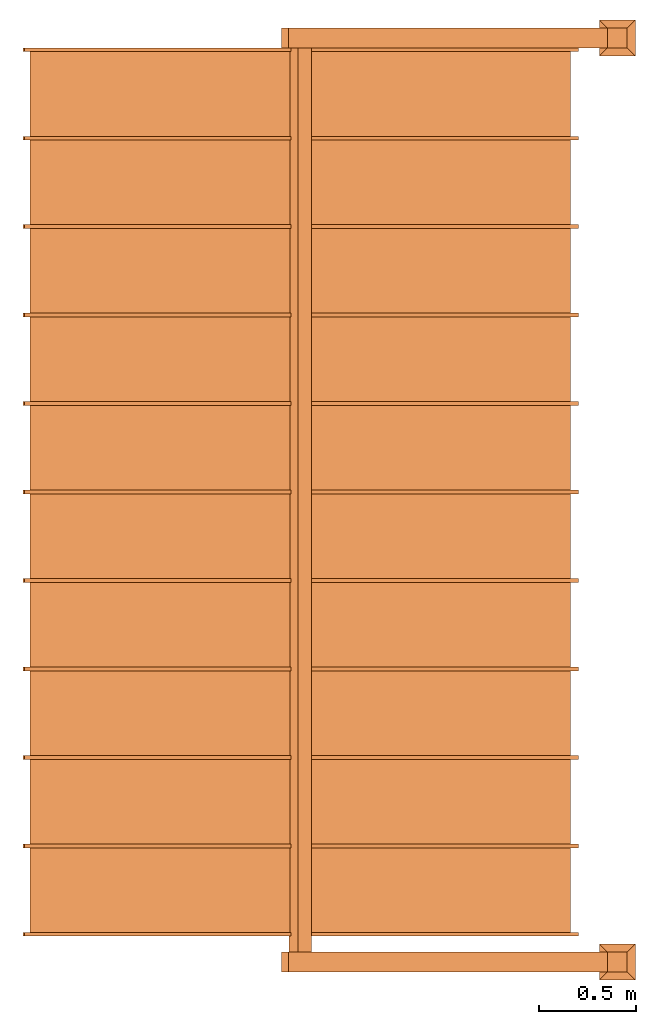
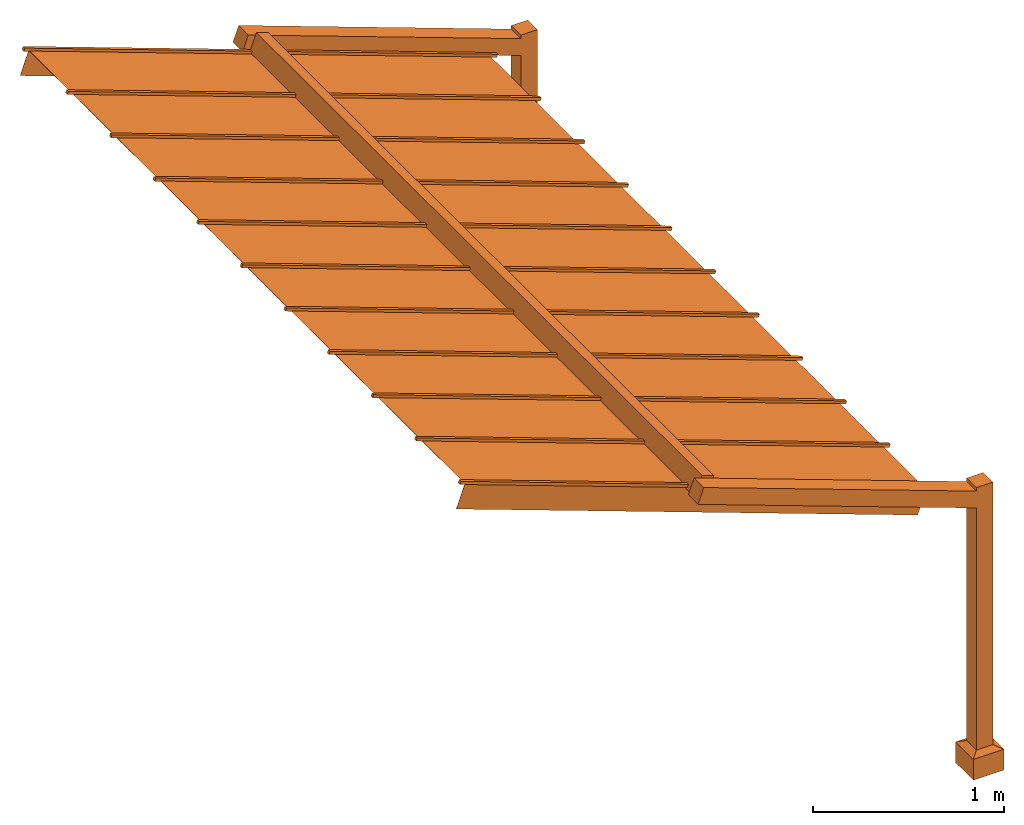
# One storey: 1 proxy.
"""IFC2X3 building model written with IfcOpenShell, lengths in feet."""

from ifc_helpers import new_model, entity, si_unit, converted_unit, derived_unit, direction, frame, origin, place, context, subcontext, project, spatial, faceted_brep, source, transform, mapped, material, material_list, type_object, type_shapes, element, save


model = new_model("IFC2X3")

# Units and contexts
model_context = context("Model", 3, precision=0.0001, world=origin(), true_north=direction((6.123031769111886e-17, 1.0)))
plan_context = context("Plan", 3, precision=0.0001, world=origin(), true_north=direction((6.123031769111886e-17, 1.0)))
body_context = subcontext(model_context, "Body", "Model", "MODEL_VIEW")
ifc_project = project(units=[converted_unit("LENGTHUNIT", "FOOT", entity("IfcRatioMeasure", 0.3048), si_unit("LENGTHUNIT", "METRE"), dimensions=[1, 0, 0, 0, 0, 0, 0]), converted_unit("AREAUNIT", "SQUARE FOOT", entity("IfcRatioMeasure", 0.09290304), si_unit("AREAUNIT", "SQUARE_METRE"), dimensions=[2, 0, 0, 0, 0, 0, 0]), converted_unit("VOLUMEUNIT", "CUBIC FOOT", entity("IfcRatioMeasure", 0.028316846592000004), si_unit("VOLUMEUNIT", "CUBIC_METRE"), dimensions=[3, 0, 0, 0, 0, 0, 0]), converted_unit("PLANEANGLEUNIT", "DEGREE", entity("IfcRatioMeasure", 0.017453292519943278), si_unit("PLANEANGLEUNIT", "RADIAN"), dimensions=[0, 0, 0, 0, 0, 0, 0]), si_unit("MASSUNIT", "GRAM", prefix="KILO"), derived_unit("MASSDENSITYUNIT", [(si_unit("MASSUNIT", "GRAM", prefix="KILO"), 1), (si_unit("LENGTHUNIT", "METRE"), -3)]), derived_unit("MOMENTOFINERTIAUNIT", [(si_unit("LENGTHUNIT", "METRE"), 4)]), si_unit("TIMEUNIT", "SECOND"), si_unit("FREQUENCYUNIT", "HERTZ"), si_unit("THERMODYNAMICTEMPERATUREUNIT", "DEGREE_CELSIUS"), derived_unit("THERMALTRANSMITTANCEUNIT", [(si_unit("MASSUNIT", "GRAM", prefix="KILO"), 1), (si_unit("THERMODYNAMICTEMPERATUREUNIT", "KELVIN"), -1), (si_unit("TIMEUNIT", "SECOND"), -3)]), derived_unit("VOLUMETRICFLOWRATEUNIT", [(si_unit("LENGTHUNIT", "METRE"), 3), (si_unit("TIMEUNIT", "SECOND"), -1)]), derived_unit("MASSFLOWRATEUNIT", [(si_unit("MASSUNIT", "GRAM", prefix="KILO"), 1), (si_unit("TIMEUNIT", "SECOND"), -1)]), derived_unit("ROTATIONALFREQUENCYUNIT", [(si_unit("TIMEUNIT", "SECOND"), -1)]), si_unit("ELECTRICCURRENTUNIT", "AMPERE"), si_unit("ELECTRICVOLTAGEUNIT", "VOLT"), si_unit("POWERUNIT", "WATT"), si_unit("FORCEUNIT", "NEWTON"), si_unit("ILLUMINANCEUNIT", "LUX"), si_unit("LUMINOUSFLUXUNIT", "LUMEN"), si_unit("LUMINOUSINTENSITYUNIT", "CANDELA"), derived_unit("USERDEFINED", [(si_unit("MASSUNIT", "GRAM", prefix="KILO"), -1), (si_unit("LENGTHUNIT", "METRE"), -2), (si_unit("TIMEUNIT", "SECOND"), 3), (si_unit("LUMINOUSFLUXUNIT", "LUMEN"), 1)]), derived_unit("SOUNDPOWERUNIT", [(si_unit("MASSUNIT", "GRAM", prefix="KILO"), 1), (si_unit("LENGTHUNIT", "METRE"), 2), (si_unit("TIMEUNIT", "SECOND"), -3)]), derived_unit("LINEARVELOCITYUNIT", [(si_unit("LENGTHUNIT", "METRE"), 1), (si_unit("TIMEUNIT", "SECOND"), -1)]), si_unit("PRESSUREUNIT", "PASCAL"), derived_unit("USERDEFINED", [(si_unit("LENGTHUNIT", "METRE"), -2), (si_unit("MASSUNIT", "GRAM", prefix="KILO"), 1), (si_unit("TIMEUNIT", "SECOND"), -2)]), derived_unit("LINEARFORCEUNIT", [(si_unit("MASSUNIT", "GRAM", prefix="KILO"), 1), (si_unit("LENGTHUNIT", "METRE"), 1), (si_unit("TIMEUNIT", "SECOND"), -2), (si_unit("LENGTHUNIT", "METRE"), -1)]), derived_unit("PLANARFORCEUNIT", [(si_unit("MASSUNIT", "GRAM", prefix="KILO"), 1), (si_unit("LENGTHUNIT", "METRE"), 1), (si_unit("TIMEUNIT", "SECOND"), -2), (si_unit("LENGTHUNIT", "METRE"), -2)])], contexts=[model_context, plan_context])

# Site, building, storey
site_placement = place(None, origin())
site = spatial("IfcSite", under=ifc_project, at=site_placement, CompositionType="ELEMENT")
building_placement = place(site_placement, origin())
building = spatial("IfcBuilding", under=site, at=building_placement, CompositionType="ELEMENT")
storey_placement = place(building_placement, origin())
storey = spatial("IfcBuildingStorey", under=building, at=storey_placement, Name="Level 1", CompositionType="ELEMENT", Elevation=0.0)

# Proxy
ifc_material_1 = material()
ifc_material_2 = material()
ifc_material_list_1 = material_list([ifc_material_1, ifc_material_2, ifc_material_1, ifc_material_2, ifc_material_1, ifc_material_2, ifc_material_1, ifc_material_2, ifc_material_1, ifc_material_2, ifc_material_1, ifc_material_2, ifc_material_1, ifc_material_2, ifc_material_1, ifc_material_2, ifc_material_1, ifc_material_2, ifc_material_1, ifc_material_2, ifc_material_2, ifc_material_2, ifc_material_1, ifc_material_1, ifc_material_1, ifc_material_1, ifc_material_1, ifc_material_1, ifc_material_1, ifc_material_1, ifc_material_1, ifc_material_1, ifc_material_1, ifc_material_1, ifc_material_1, ifc_material_1, ifc_material_1, ifc_material_1])
ifc_material_list_2 = material_list([ifc_material_1, ifc_material_2, ifc_material_1, ifc_material_2, ifc_material_1, ifc_material_2, ifc_material_1, ifc_material_2, ifc_material_1, ifc_material_2, ifc_material_1, ifc_material_2, ifc_material_1, ifc_material_2, ifc_material_1, ifc_material_2, ifc_material_1, ifc_material_2, ifc_material_1, ifc_material_2, ifc_material_2, ifc_material_2, ifc_material_1, ifc_material_1, ifc_material_1, ifc_material_1, ifc_material_1, ifc_material_1, ifc_material_1, ifc_material_1, ifc_material_1, ifc_material_1, ifc_material_1, ifc_material_1, ifc_material_1, ifc_material_1, ifc_material_1, ifc_material_1])
building_element_proxy_type = type_object("IfcBuildingElementProxyType", PredefinedType="NOTDEFINED", material=ifc_material_list_2)
shared_shape = source(origin(), body_context, "Body", "Brep", [
    faceted_brep([(-4.481523158329109, 3.604166666665547, 9.237581505428055), (4.915403049529978, 3.60416666666538, 5.817380072171364), (4.915403049529979, 3.6666666666653196, 5.817380072171363), (-4.481523158329107, 3.6666666666654866, 9.237581505428055), (-4.502899417286965, 3.604166666665547, 9.178850716628936), (-4.502899417286962, 3.6666666666654866, 9.178850716628936), (4.894026790572124, 3.6666666666653196, 5.758649283372244), (4.8940267905721235, 3.60416666666538, 5.758649283372245)], [[[0, 1, 2, 3]], [[4, 5, 6, 7]], [[1, 0, 4, 7]], [[2, 1, 7, 6]], [[3, 2, 6, 5]], [[0, 3, 5, 4]]]),
    faceted_brep([(-4.383656484775557, 3.6041666666655647, 9.14099243111315), (-4.383656484775579, 2.166666666665572, 9.140992431113158), (4.778346567887023, 2.1666666666653867, 5.806296033687887), (4.778346567887044, 3.604166666665402, 5.806296033687877), (-4.385437839688711, 3.604166666665565, 9.136098198713222), (4.77656521297389, 3.604166666665402, 5.80140180128795), (4.77656521297387, 2.1666666666653867, 5.801401801287959), (-4.385437839688733, 2.166666666665572, 9.136098198713231)], [[[0, 1, 2, 3]], [[4, 5, 6, 7]], [[2, 1, 7, 6]], [[0, 3, 5, 4]], [[1, 0, 4, 7]], [[3, 2, 6, 5]]]),
    faceted_brep([(-4.481523158329136, 2.104166666665483, 9.237581505428055), (4.915403049529951, 2.104166666665316, 5.817380072171364), (4.915403049529952, 2.1666666666652556, 5.817380072171363), (-4.481523158329134, 2.1666666666654226, 9.237581505428055), (-4.502899417286992, 2.104166666665483, 9.178850716628936), (-4.502899417286988, 2.1666666666654226, 9.178850716628936), (4.894026790572098, 2.1666666666652556, 5.758649283372244), (4.894026790572097, 2.104166666665316, 5.758649283372245)], [[[0, 1, 2, 3]], [[4, 5, 6, 7]], [[1, 0, 4, 7]], [[2, 1, 7, 6]], [[3, 2, 6, 5]], [[0, 3, 5, 4]]]),
    faceted_brep([(-4.3836564847755835, 2.104166666665501, 9.14099243111315), (-4.383656484775606, 0.6666666666655079, 9.140992431113158), (4.778346567886996, 0.6666666666653226, 5.806296033687887), (4.778346567887017, 2.1041666666653382, 5.806296033687877), (-4.385437839688738, 2.1041666666655012, 9.136098198713222), (4.776565212973863, 2.1041666666653382, 5.80140180128795), (4.776565212973844, 0.6666666666653226, 5.801401801287959), (-4.38543783968876, 0.6666666666655079, 9.136098198713231)], [[[0, 1, 2, 3]], [[4, 5, 6, 7]], [[2, 1, 7, 6]], [[0, 3, 5, 4]], [[1, 0, 4, 7]], [[3, 2, 6, 5]]]),
    faceted_brep([(-4.481523158329162, 0.6041666666654191, 9.237581505428055), (4.915403049529925, 0.6041666666652521, 5.817380072171364), (4.9154030495299255, 0.6666666666651919, 5.817380072171363), (-4.481523158329161, 0.6666666666653589, 9.237581505428055), (-4.5028994172870185, 0.6041666666654191, 9.178850716628936), (-4.502899417287015, 0.6666666666653589, 9.178850716628936), (4.894026790572071, 0.6666666666651919, 5.758649283372244), (4.89402679057207, 0.6041666666652521, 5.758649283372245)], [[[0, 1, 2, 3]], [[4, 5, 6, 7]], [[1, 0, 4, 7]], [[2, 1, 7, 6]], [[3, 2, 6, 5]], [[0, 3, 5, 4]]]),
    faceted_brep([(-4.38365648477561, 0.6041666666654371, 9.14099243111315), (-4.383656484775632, -0.8333333333345561, 9.140992431113158), (4.778346567886969, -0.8333333333347414, 5.806296033687887), (4.778346567886991, 0.6041666666652743, 5.806296033687877), (-4.385437839688764, 0.6041666666654373, 9.136098198713222), (4.7765652129738365, 0.6041666666652745, 5.80140180128795), (4.776565212973817, -0.8333333333347414, 5.801401801287959), (-4.3854378396887865, -0.8333333333345561, 9.136098198713231)], [[[0, 1, 2, 3]], [[4, 5, 6, 7]], [[2, 1, 7, 6]], [[0, 3, 5, 4]], [[1, 0, 4, 7]], [[3, 2, 6, 5]]]),
    faceted_brep([(-4.481523158329189, -0.8958333333346449, 9.237581505428055), (4.915403049529898, -0.8958333333348119, 5.817380072171364), (4.915403049529899, -0.833333333334872, 5.817380072171363), (-4.481523158329187, -0.833333333334705, 9.237581505428055), (-4.502899417287045, -0.8958333333346449, 9.178850716628936), (-4.502899417287042, -0.833333333334705, 9.178850716628936), (4.8940267905720445, -0.833333333334872, 5.758649283372244), (4.894026790572044, -0.8958333333348119, 5.758649283372245)], [[[0, 1, 2, 3]], [[4, 5, 6, 7]], [[1, 0, 4, 7]], [[2, 1, 7, 6]], [[3, 2, 6, 5]], [[0, 3, 5, 4]]]),
    faceted_brep([(-4.383656484775637, -0.8958333333346269, 9.14099243111315), (-4.383656484775659, -2.33333333333462, 9.140992431113158), (4.778346567886943, -2.333333333334805, 5.806296033687887), (4.778346567886964, -0.8958333333347896, 5.806296033687877), (-4.385437839688791, -0.8958333333346267, 9.136098198713222), (4.77656521297381, -0.8958333333347894, 5.80140180128795), (4.77656521297379, -2.333333333334805, 5.801401801287959), (-4.385437839688813, -2.33333333333462, 9.136098198713231)], [[[0, 1, 2, 3]], [[4, 5, 6, 7]], [[2, 1, 7, 6]], [[0, 3, 5, 4]], [[1, 0, 4, 7]], [[3, 2, 6, 5]]]),
    faceted_brep([(-4.481523158329216, -2.395833333334709, 9.237581505428055), (4.915403049529871, -2.395833333334876, 5.817380072171364), (4.915403049529872, -2.333333333334936, 5.817380072171363), (-4.481523158329214, -2.333333333334769, 9.237581505428055), (-4.502899417287072, -2.395833333334709, 9.178850716628936), (-4.502899417287068, -2.333333333334769, 9.178850716628936), (4.894026790572018, -2.333333333334936, 5.758649283372244), (4.894026790572017, -2.395833333334876, 5.758649283372245)], [[[0, 1, 2, 3]], [[4, 5, 6, 7]], [[1, 0, 4, 7]], [[2, 1, 7, 6]], [[3, 2, 6, 5]], [[0, 3, 5, 4]]]),
    faceted_brep([(-4.383656484775663, -2.395833333334692, 9.14099243111315), (-4.383656484775686, -3.833333333334685, 9.140992431113158), (4.778346567886916, -3.83333333333487, 5.806296033687887), (4.7783465678869375, -2.3958333333348545, 5.806296033687877), (-4.385437839688818, -2.3958333333346915, 9.136098198713222), (4.776565212973783, -2.3958333333348545, 5.80140180128795), (4.776565212973764, -3.83333333333487, 5.801401801287959), (-4.38543783968884, -3.833333333334685, 9.136098198713231)], [[[0, 1, 2, 3]], [[4, 5, 6, 7]], [[2, 1, 7, 6]], [[0, 3, 5, 4]], [[1, 0, 4, 7]], [[3, 2, 6, 5]]]),
    faceted_brep([(-4.481523158329242, -3.8958333333347728, 9.237581505428055), (4.915403049529845, -3.8958333333349398, 5.817380072171364), (4.9154030495298455, -3.833333333335, 5.817380072171363), (-4.4815231583292405, -3.833333333334833, 9.237581505428055), (-4.502899417287098, -3.8958333333347728, 9.178850716628936), (-4.502899417287095, -3.833333333334833, 9.178850716628936), (4.894026790571991, -3.833333333335, 5.758649283372244), (4.89402679057199, -3.8958333333349398, 5.758649283372245)], [[[0, 1, 2, 3]], [[4, 5, 6, 7]], [[1, 0, 4, 7]], [[2, 1, 7, 6]], [[3, 2, 6, 5]], [[0, 3, 5, 4]]]),
    faceted_brep([(-4.38365648477569, -3.895833333334757, 9.14099243111315), (-4.383656484775712, -5.33333333333475, 9.140992431113158), (4.7783465678868895, -5.333333333334935, 5.806296033687887), (4.778346567886911, -3.8958333333349193, 5.806296033687877), (-4.385437839688844, -3.8958333333347563, 9.136098198713222), (4.776565212973757, -3.8958333333349193, 5.80140180128795), (4.776565212973737, -5.333333333334935, 5.801401801287959), (-4.3854378396888665, -5.33333333333475, 9.136098198713231)], [[[0, 1, 2, 3]], [[4, 5, 6, 7]], [[2, 1, 7, 6]], [[0, 3, 5, 4]], [[1, 0, 4, 7]], [[3, 2, 6, 5]]]),
    faceted_brep([(-4.481523158329269, -5.395833333334836, 9.237581505428055), (4.915403049529818, -5.395833333335003, 5.817380072171364), (4.915403049529819, -5.333333333335063, 5.817380072171363), (-4.481523158329267, -5.333333333334896, 9.237581505428055), (-4.502899417287125, -5.395833333334837, 9.178850716628936), (-4.5028994172871215, -5.333333333334897, 9.178850716628936), (4.8940267905719645, -5.333333333335064, 5.758649283372244), (4.894026790571964, -5.395833333335004, 5.758649283372245)], [[[0, 1, 2, 3]], [[4, 5, 6, 7]], [[1, 0, 4, 7]], [[2, 1, 7, 6]], [[3, 2, 6, 5]], [[0, 3, 5, 4]]]),
    faceted_brep([(-4.383656484775717, -5.39583333333482, 9.14099243111315), (-4.383656484775739, -6.833333333334813, 9.140992431113158), (4.778346567886863, -6.833333333334998, 5.806296033687887), (4.778346567886884, -5.395833333334982, 5.806296033687877), (-4.385437839688871, -5.395833333334819, 9.136098198713222), (4.77656521297373, -5.395833333334982, 5.80140180128795), (4.77656521297371, -6.833333333334998, 5.801401801287959), (-4.385437839688893, -6.833333333334813, 9.136098198713231)], [[[0, 1, 2, 3]], [[4, 5, 6, 7]], [[2, 1, 7, 6]], [[0, 3, 5, 4]], [[1, 0, 4, 7]], [[3, 2, 6, 5]]]),
    faceted_brep([(-4.481523158329296, -6.895833333334899, 9.237581505428055), (4.915403049529791, -6.895833333335066, 5.817380072171364), (4.915403049529792, -6.833333333335126, 5.817380072171363), (-4.481523158329294, -6.833333333334959, 9.237581505428055), (-4.502899417287152, -6.8958333333349, 9.178850716628936), (-4.502899417287148, -6.83333333333496, 9.178850716628936), (4.894026790571938, -6.833333333335127, 5.758649283372244), (4.894026790571937, -6.895833333335067, 5.758649283372245)], [[[0, 1, 2, 3]], [[4, 5, 6, 7]], [[1, 0, 4, 7]], [[2, 1, 7, 6]], [[3, 2, 6, 5]], [[0, 3, 5, 4]]]),
    faceted_brep([(-4.383656484775743, -6.895833333334883, 9.14099243111315), (-4.3836564847757655, -8.333333333334876, 9.140992431113158), (4.778346567886836, -8.33333333333506, 5.806296033687887), (4.7783465678868575, -6.8958333333350454, 5.806296033687877), (-4.3854378396888976, -6.895833333334883, 9.136098198713222), (4.776565212973703, -6.8958333333350454, 5.80140180128795), (4.776565212973684, -8.33333333333506, 5.801401801287959), (-4.38543783968892, -8.333333333334876, 9.136098198713231)], [[[0, 1, 2, 3]], [[4, 5, 6, 7]], [[2, 1, 7, 6]], [[0, 3, 5, 4]], [[1, 0, 4, 7]], [[3, 2, 6, 5]]]),
    faceted_brep([(-4.481523158329322, -8.395833333334963, 9.237581505428055), (4.915403049529765, -8.39583333333513, 5.817380072171364), (4.915403049529766, -8.33333333333519, 5.817380072171363), (-4.4815231583293205, -8.333333333335023, 9.237581505428055), (-4.502899417287178, -8.395833333334963, 9.178850716628936), (-4.502899417287175, -8.333333333335023, 9.178850716628936), (4.894026790571911, -8.33333333333519, 5.758649283372244), (4.89402679057191, -8.39583333333513, 5.758649283372245)], [[[0, 1, 2, 3]], [[4, 5, 6, 7]], [[1, 0, 4, 7]], [[2, 1, 7, 6]], [[3, 2, 6, 5]], [[0, 3, 5, 4]]]),
    faceted_brep([(-4.38365648477577, -8.395833333334947, 9.14099243111315), (-4.383656484775792, -9.83333333333494, 9.140992431113158), (4.77834656788681, -9.833333333335124, 5.806296033687887), (4.778346567886831, -8.395833333335109, 5.806296033687877), (-4.385437839688924, -8.395833333334947, 9.136098198713222), (4.776565212973677, -8.395833333335109, 5.80140180128795), (4.776565212973657, -9.833333333335124, 5.801401801287959), (-4.385437839688946, -9.83333333333494, 9.136098198713231)], [[[0, 1, 2, 3]], [[4, 5, 6, 7]], [[2, 1, 7, 6]], [[0, 3, 5, 4]], [[1, 0, 4, 7]], [[3, 2, 6, 5]]]),
    faceted_brep([(-4.481523158329349, -9.895833333335027, 9.237581505428055), (4.915403049529738, -9.895833333335194, 5.817380072171364), (4.915403049529739, -9.833333333335254, 5.817380072171363), (-4.481523158329347, -9.833333333335087, 9.237581505428055), (-4.502899417287205, -9.895833333335029, 9.178850716628936), (-4.5028994172872014, -9.833333333335089, 9.178850716628936), (4.894026790571885, -9.833333333335256, 5.758649283372244), (4.894026790571884, -9.895833333335196, 5.758649283372245)], [[[0, 1, 2, 3]], [[4, 5, 6, 7]], [[1, 0, 4, 7]], [[2, 1, 7, 6]], [[3, 2, 6, 5]], [[0, 3, 5, 4]]]),
    faceted_brep([(-4.383656484775797, -9.89583333333501, 9.14099243111315), (-4.383656484775819, -11.333333333335004, 9.140992431113158), (4.778346567886783, -11.333333333335188, 5.806296033687887), (4.778346567886804, -9.895833333335172, 5.806296033687877), (-4.385437839688951, -9.89583333333501, 9.136098198713222), (4.77656521297365, -9.895833333335172, 5.80140180128795), (4.7765652129736305, -11.333333333335188, 5.801401801287959), (-4.385437839688973, -11.333333333335004, 9.136098198713231)], [[[0, 1, 2, 3]], [[4, 5, 6, 7]], [[2, 1, 7, 6]], [[0, 3, 5, 4]], [[1, 0, 4, 7]], [[3, 2, 6, 5]]]),
    faceted_brep([(-4.385437839688735, 3.6406249999981886, 9.136098198713142), (-4.556447911351496, 3.6406249999981917, 8.666251888320371), (-4.556447911351496, 3.6354166666648595, 8.666251888320371), (-4.385437839688736, 3.6354166666648564, 9.136098198713142), (4.776565212973941, 3.640624999998009, 5.801401801287988), (4.77656521297394, 3.635416666664677, 5.801401801287988), (4.60555514131118, 3.63541666666468, 5.331555490895217), (4.60555514131118, 3.6406249999980123, 5.331555490895217)], [[[0, 1, 2, 3]], [[4, 5, 6, 7]], [[1, 0, 4, 7]], [[2, 1, 7, 6]], [[3, 2, 6, 5]], [[0, 3, 5, 4]]]),
    faceted_brep([(-4.556447911351842, -11.363090277779488, 8.666251888320227), (-4.385437839689014, -11.363090277779492, 9.136098198713185), (4.776565212973662, -11.363090277779673, 5.801401801288031), (4.605555141310836, -11.36309027777967, 5.331555490895073), (-4.556447911351842, -11.368298611112822, 8.666251888320227), (4.605555141310836, -11.368298611113003, 5.331555490895074), (-4.385437839689014, -11.368298611112825, 9.136098198713185), (4.776565212973664, -11.368298611113007, 5.80140180128803)], [[[0, 1, 2, 3]], [[4, 0, 3, 5]], [[6, 4, 5, 7]], [[1, 6, 7, 2]], [[2, 7, 5, 3]], [[1, 0, 4, 6]]]),
    faceted_brep([(-4.481523158329393, -11.33333333333502, 9.237581505427958), (-4.502899417287248, -11.33333333333502, 9.178850716628835), (-4.5028994172872485, -11.395833333335021, 9.178850716628835), (-4.481523158329394, -11.395833333335023, 9.237581505427958), (4.9154030495297665, -11.333333333335187, 5.817380072171498), (4.915403049529766, -11.39583333333519, 5.817380072171498), (4.894026790571911, -11.395833333335188, 5.758649283372375), (4.894026790571912, -11.333333333335187, 5.758649283372375)], [[[0, 1, 2, 3]], [[4, 5, 6, 7]], [[1, 0, 4, 7]], [[2, 1, 7, 6]], [[3, 2, 6, 5]], [[0, 3, 5, 4]]]),
    faceted_brep([(0.011801221819146335, -12.0, 7.900497029450574), (0.011801221819146477, -11.666666666667663, 7.900497029450574), (-0.1022054926227436, -11.666666666667663, 7.587266155855271), (-0.10220549262274359, -12.0, 7.587266155855271), (-0.09508007297012538, -11.687500000000997, 7.606843085454979), (0.004675802166528404, -11.687500000000997, 7.880920099850869), (0.004675802166528404, -11.979166666667663, 7.880920099850869), (-0.09508007297012538, -11.979166666667663, 7.606843085454979), (5.403897019976151, -12.0, 5.937934658609555), (5.403897019976151, -11.666666666667663, 5.937934658609555), (5.403897019976151, -11.666666666667663, 5.583208734450917), (5.403897019976151, -12.0, 5.583208734450917), (5.403897019976152, -11.687500000000995, 5.605379104710831), (5.403897019976151, -11.687500000000995, 5.91576428834964), (5.403897019976151, -11.979166666667663, 5.91576428834964), (5.40389701997615, -11.979166666667663, 5.605379104710832)], [[[0, 1, 2, 3], [4, 5, 6, 7]], [[1, 0, 8, 9]], [[2, 1, 9, 10]], [[3, 2, 10, 11]], [[0, 3, 11, 8]], [[5, 4, 12, 13]], [[6, 5, 13, 14]], [[7, 6, 14, 15]], [[4, 7, 15, 12]], [[9, 8, 11, 10], [13, 12, 15, 14]]]),
    faceted_brep([(5.425614074147084, -11.687500000000997, 5.597474743416666), (5.425614074147084, -11.979166666667604, 5.597474743416666), (5.424730353309081, -11.979166666667604, 5.595046740369151), (5.424730353309082, -11.687500000001023, 5.5950467403691535), (5.424730353309082, -11.687500000000997, 5.5977963914970985), (5.424730353309081, -11.979166666667604, 5.597796391497099)], [[[0, 1, 2, 3]], [[1, 0, 4, 5]], [[5, 2, 1]], [[2, 5, 4, 3]], [[3, 4, 0]]]),
    faceted_brep([(5.532495368936356, -11.979166666667604, 5.891128687412262), (5.532495368936354, -11.687500000001023, 5.891128687412262), (5.424730353309081, -11.687500000001023, 5.930351945395823), (5.424730353309081, -11.979166666667604, 5.930351945395823), (5.525369949283738, -11.687500000000997, 5.871551757812556), (5.525369949283738, -11.979166666667604, 5.871551757812555), (5.424730353309081, -11.97916666666766, 5.908181575135908), (5.424730353309081, -11.687500000001023, 5.908181575135908)], [[[0, 1, 2, 3]], [[4, 5, 6, 7]], [[5, 4, 1, 0]], [[3, 6, 5, 0]], [[6, 3, 2, 7]], [[7, 2, 1, 4]]]),
    faceted_brep([(-0.10220549262274493, -12.0, 7.587266155855271), (0.011801221819145447, -12.0, 7.900497029450573), (-0.007775707780560918, -12.0, 7.907622449103192), (-0.12178242222245131, -12.0, 7.594391575507889), (-0.10220549262274493, -11.666666666667663, 7.587266155855271), (-0.12178242222245131, -11.666666666667663, 7.594391575507889), (-0.007775707780561809, -11.666666666667663, 7.907622449103192), (0.011801221819145447, -11.666666666667663, 7.900497029450573)], [[[0, 1, 2, 3]], [[4, 5, 6, 7]], [[1, 0, 4, 7]], [[2, 1, 7, 6]], [[3, 2, 6, 5]], [[0, 3, 5, 4]]]),
    faceted_brep([(0.011801221818585006, 3.666666666665422, 7.900497029450574), (0.011801221818585148, 4.0, 7.900497029450574), (-0.10220549262330493, 4.0, 7.587266155855271), (-0.10220549262330492, 3.666666666665422, 7.587266155855271), (-0.09508007297068671, 3.979166666665422, 7.606843085454979), (0.004675802165967075, 3.979166666665422, 7.880920099850869), (0.004675802165967075, 3.6874999999987557, 7.880920099850869), (-0.09508007297068671, 3.6874999999987557, 7.606843085454979), (5.532495368935795, 3.666666666665422, 5.891128687412262), (5.418488654493904, 3.666666666665422, 5.57789781381696), (5.418488654493904, 4.0, 5.57789781381696), (5.532495368935795, 4.0, 5.891128687412262), (5.425614074146523, 3.979166666665422, 5.597474743416666), (5.425614074146523, 3.6874999999987557, 5.597474743416666), (5.525369949283177, 3.6874999999987557, 5.871551757812556), (5.525369949283177, 3.979166666665422, 5.871551757812556)], [[[0, 1, 2, 3], [4, 5, 6, 7]], [[8, 9, 10, 11], [12, 13, 14, 15]], [[1, 0, 8, 11]], [[2, 1, 11, 10]], [[3, 2, 10, 9]], [[0, 3, 9, 8]], [[5, 4, 12, 15]], [[6, 5, 15, 14]], [[7, 6, 14, 13]], [[4, 7, 13, 12]]]),
    faceted_brep([(-0.10220549262330626, 3.6666666666654226, 7.587266155855271), (0.011801221818584118, 3.6666666666654226, 7.900497029450573), (-0.0077757077811222465, 3.6666666666654226, 7.907622449103192), (-0.12178242222301264, 3.6666666666654226, 7.594391575507889), (-0.10220549262330626, 4.0, 7.587266155855271), (-0.12178242222301264, 4.0, 7.594391575507889), (-0.007775707781123138, 4.0, 7.907622449103192), (0.011801221818584118, 4.0, 7.900497029450573)], [[[0, 1, 2, 3]], [[4, 5, 6, 7]], [[1, 0, 4, 7]], [[2, 1, 7, 6]], [[3, 2, 6, 5]], [[0, 3, 5, 4]]]),
    faceted_brep([(5.737230353308917, 4.0, 5.98958333333367), (5.403897019976162, 4.0, 5.98958333333367), (5.403897019976162, 3.6666666666652414, 5.98958333333367), (5.737230353308917, 3.6666666666652414, 5.98958333333367), (5.716397019975584, 3.9791666666652135, 5.98958333333367), (5.716397019975584, 3.6874999999986318, 5.98958333333367), (5.4247303533090925, 3.6874999999986318, 5.98958333333367), (5.4247303533090925, 3.9791666666652135, 5.98958333333367), (5.737230353308917, 4.0, 0.49999999999992345), (5.737230353308917, 3.6666666666652414, 0.49999999999992345), (5.403897019976162, 3.6666666666652414, 0.49999999999992345), (5.403897019976162, 4.0, 0.49999999999992345), (5.716397019975584, 3.9791666666652135, 0.49999999999992345), (5.4247303533090925, 3.9791666666652135, 0.49999999999992345), (5.4247303533090925, 3.6874999999986318, 0.49999999999992345), (5.716397019975584, 3.6874999999986318, 0.49999999999992345)], [[[0, 1, 2, 3], [4, 5, 6, 7]], [[8, 9, 10, 11], [12, 13, 14, 15]], [[1, 0, 8, 11]], [[2, 1, 11, 10]], [[3, 2, 10, 9]], [[0, 3, 9, 8]], [[5, 4, 12, 15]], [[6, 5, 15, 14]], [[7, 6, 14, 13]], [[4, 7, 13, 12]]]),
    faceted_brep([(5.4038970199761795, 4.0, 6.010416666667001), (5.4038970199761795, 3.6666666666652414, 6.010416666667001), (5.737230353308934, 3.6666666666652414, 6.010416666667), (5.737230353308934, 4.0, 6.010416666667), (5.4038970199761795, 4.0, 5.98958333333367), (5.737230353308934, 4.0, 5.989583333333669), (5.737230353308934, 3.6666666666652414, 5.989583333333669), (5.4038970199761795, 3.6666666666652414, 5.98958333333367)], [[[0, 1, 2, 3]], [[4, 5, 6, 7]], [[1, 0, 4, 7]], [[2, 1, 7, 6]], [[3, 2, 6, 5]], [[0, 3, 5, 4]]]),
    faceted_brep([(5.737230353308906, -11.666666666667663, 5.98958333333367), (5.403897019976151, -11.666666666667663, 5.98958333333367), (5.403897019976151, -12.0, 5.98958333333367), (5.737230353308906, -12.0, 5.98958333333367), (5.716397019975573, -11.687500000001023, 5.98958333333367), (5.716397019975573, -11.979166666667604, 5.98958333333367), (5.424730353309082, -11.979166666667604, 5.98958333333367), (5.424730353309082, -11.687500000001023, 5.98958333333367), (5.737230353308906, -11.666666666667663, 0.49999999999992345), (5.737230353308906, -12.0, 0.49999999999992345), (5.403897019976151, -12.0, 0.49999999999992345), (5.403897019976151, -11.666666666667663, 0.49999999999992345), (5.716397019975573, -11.687500000001023, 0.49999999999992345), (5.424730353309082, -11.687500000001023, 0.49999999999992345), (5.424730353309082, -11.979166666667604, 0.49999999999992345), (5.716397019975573, -11.979166666667604, 0.49999999999992345), (5.403897019976151, -11.666666666667663, 5.583208734450917), (5.403897019976151, -11.666666666667663, 5.937934658609555), (5.403897019976151, -12.0, 5.583208734450917), (5.403897019976151, -12.0, 5.937934658609555), (5.424730353309082, -11.979166666667602, 5.595046740369153), (5.424730353309082, -11.979166666667602, 5.5977963914971), (5.424730353309082, -11.979166666667602, 5.908181575135907), (5.424730353309082, -11.979166666667602, 5.930351945395822), (5.424730353309082, -11.687500000001023, 5.595046740369153), (5.424730353309082, -11.687500000001023, 5.5977963914970985), (5.424730353309082, -11.687500000001023, 5.908181575135907), (5.424730353309082, -11.687500000001023, 5.930351945395822)], [[[0, 1, 2, 3], [4, 5, 6, 7]], [[8, 9, 10, 11], [12, 13, 14, 15]], [[1, 0, 8, 11, 16, 17]], [[2, 1, 17, 16, 11, 10, 18, 19]], [[3, 2, 19, 18, 10, 9]], [[0, 3, 9, 8]], [[5, 4, 12, 15]], [[6, 5, 15, 14, 20, 21, 22, 23]], [[7, 6, 23, 22, 21, 20, 14, 13, 24, 25, 26, 27]], [[4, 7, 27, 26, 25, 24, 13, 12]]]),
    faceted_brep([(5.403897019976169, -11.666666666667663, 6.010416666667001), (5.403897019976169, -12.0, 6.010416666667001), (5.737230353308924, -12.0, 6.010416666667), (5.737230353308924, -11.666666666667663, 6.010416666667), (5.403897019976169, -11.666666666667663, 5.98958333333367), (5.737230353308924, -11.666666666667663, 5.989583333333669), (5.737230353308924, -12.0, 5.989583333333669), (5.403897019976169, -12.0, 5.98958333333367)], [[[0, 1, 2, 3]], [[4, 5, 6, 7]], [[1, 0, 4, 7]], [[2, 1, 7, 6]], [[3, 2, 6, 5]], [[0, 3, 5, 4]]]),
    faceted_brep([(5.7372303533092355, -11.66666666666772, 0.49999999999991734), (5.4038970199759016, -11.66666666666772, 0.49999999999991734), (5.4038970199759016, -12.0, 0.49999999999991734), (5.737230353309235, -12.0, 0.49999999999991734), (5.875147019975902, -11.528750000001052, 0.4365234374999176), (5.875147019975903, -12.13791666666772, 0.4365234374999176), (5.265980353309233, -12.137916666667723, 0.4365234374999175), (5.265980353309234, -11.52875000000105, 0.4365234374999176)], [[[0, 1, 2, 3]], [[4, 5, 6, 7]], [[4, 7, 1, 0]], [[7, 6, 2, 1]], [[6, 5, 3, 2]], [[5, 4, 0, 3]]]),
    faceted_brep([(5.265980353309233, -11.52875000000105, 0.43652343749991734), (5.265980353309232, -12.137916666667719, 0.43652343749991734), (5.875147019975902, -12.13791666666772, 0.43652343749991734), (5.875147019975903, -11.528750000001054, 0.43652343749991734), (5.265980353309233, -11.52875000000105, 0.0), (5.875147019975903, -11.528750000001054, 0.0), (5.875147019975902, -12.13791666666772, 0.0), (5.265980353309232, -12.137916666667719, 0.0)], [[[0, 1, 2, 3]], [[4, 5, 6, 7]], [[1, 0, 4, 7]], [[2, 1, 7, 6]], [[3, 2, 6, 5]], [[0, 3, 5, 4]]]),
    faceted_brep([(5.737230353309243, 4.0, 0.49999999999991734), (5.40389701997591, 4.0, 0.49999999999991734), (5.403897019975909, 3.666666666665543, 0.49999999999991734), (5.7372303533092435, 3.6666666666655425, 0.49999999999991734), (5.875147019975911, 4.137916666665545, 0.4365234374999176), (5.87514701997591, 3.5287499999988743, 0.4365234374999176), (5.265980353309242, 3.5287499999988747, 0.4365234374999175), (5.265980353309241, 4.137916666665544, 0.4365234374999176)], [[[0, 1, 2, 3]], [[4, 5, 6, 7]], [[4, 7, 1, 0]], [[7, 6, 2, 1]], [[6, 5, 3, 2]], [[5, 4, 0, 3]]]),
    faceted_brep([(5.265980353309242, 4.137916666665544, 0.43652343749991734), (5.265980353309241, 3.528749999998876, 0.43652343749991734), (5.875147019975911, 3.5287499999988743, 0.43652343749991734), (5.875147019975912, 4.137916666665542, 0.43652343749991734), (5.265980353309242, 4.137916666665544, 0.0), (5.875147019975912, 4.137916666665542, 0.0), (5.875147019975911, 3.5287499999988743, 0.0), (5.265980353309241, 3.528749999998876, 0.0)], [[[0, 1, 2, 3]], [[4, 5, 6, 7]], [[1, 0, 4, 7]], [[2, 1, 7, 6]], [[3, 2, 6, 5]], [[0, 3, 5, 4]]]),
    faceted_brep([(0.1529190153970852, 3.66666666666557, 7.904560278712629), (0.3878421705935269, 3.666666666665569, 7.819055242881224), (0.23820835788854386, 3.6666666666655696, 7.407939721287387), (0.003285202692102196, 3.6666666666655705, 7.493444757118792), (0.15291901539703456, -11.666666666667574, 7.904560278712629), (0.00328520269205157, -11.666666666667572, 7.493444757118792), (0.23820835788849323, -11.666666666667574, 7.407939721287387), (0.38784217059347625, -11.666666666667574, 7.819055242881224)], [[[0, 1, 2, 3]], [[4, 5, 6, 7]], [[0, 3, 5, 4]], [[3, 2, 6, 5]], [[2, 1, 7, 6]], [[1, 0, 4, 7]]]),
])
type_shapes(building_element_proxy_type, [shared_shape])
proxy_placement = place(storey_placement, frame((-5.737230353308772, -4.0, 0.0)))
element("IfcBuildingElementProxy", 1, at=proxy_placement, inside=storey, type_object=building_element_proxy_type, material=ifc_material_list_1, context=body_context, shape_type="MappedRepresentation", body=[
    mapped(shared_shape, transform((0.0, 0.0, 0.0), scale=1.0)),
])

save(model, "model.ifc")
